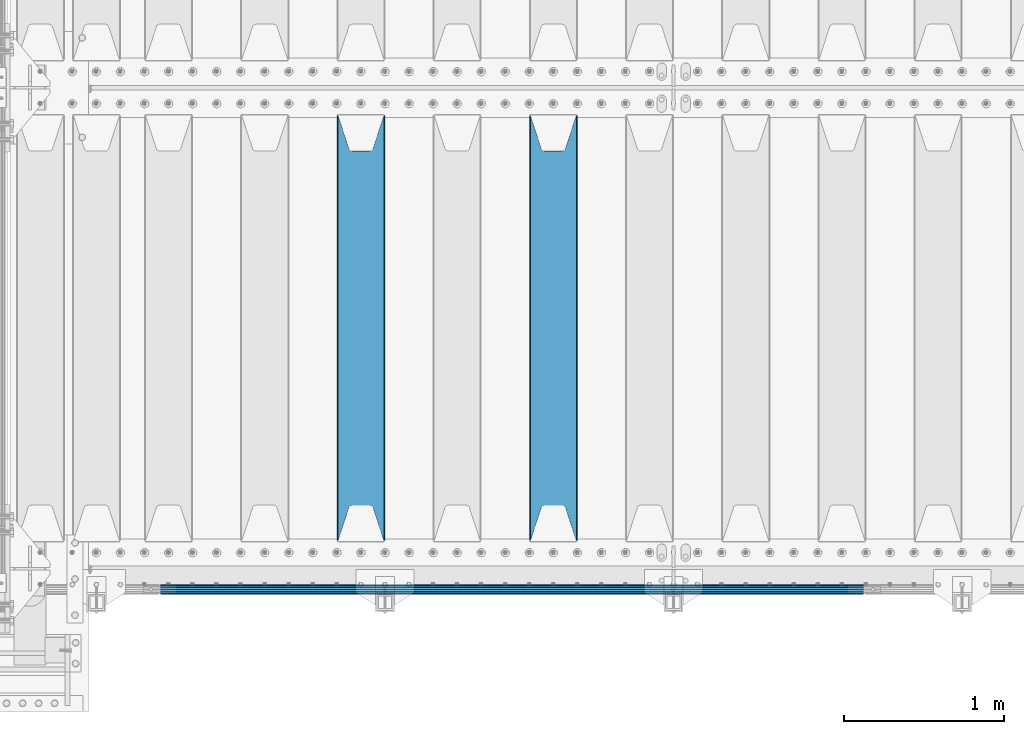
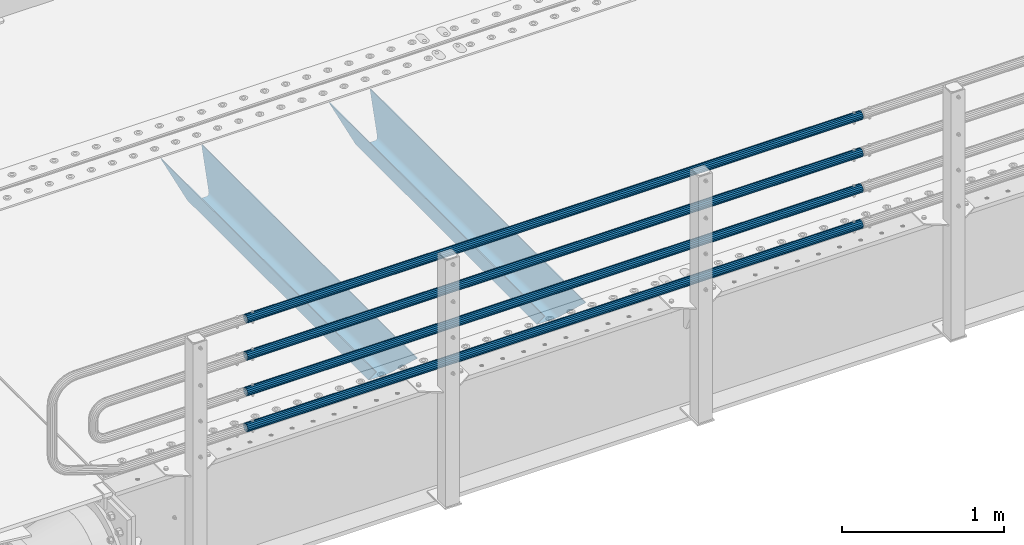
# One storey, part 86 of 193: 6 beams.
"""IFC2X3 building model written with IfcOpenShell, lengths in millimetres."""

from ifc_helpers import new_model, si_unit, frame, origin_with_axes, place, context, subcontext, project, spatial, faceted_brep, material, type_object, element, save


model = new_model("IFC2X3")

# Units and contexts
model_context = context("Model", 3, precision=1e-05, world=origin_with_axes())
body_context = subcontext(model_context, "Body", "Model", "MODEL_VIEW")
ifc_project = project(units=[si_unit("LENGTHUNIT", "METRE", prefix="MILLI"), si_unit("AREAUNIT", "SQUARE_METRE"), si_unit("VOLUMEUNIT", "CUBIC_METRE"), si_unit("MASSUNIT", "GRAM", prefix="KILO"), si_unit("TIMEUNIT", "SECOND"), si_unit("PLANEANGLEUNIT", "RADIAN"), si_unit("SOLIDANGLEUNIT", "STERADIAN"), si_unit("THERMODYNAMICTEMPERATUREUNIT", "DEGREE_CELSIUS"), si_unit("LUMINOUSINTENSITYUNIT", "LUMEN")], contexts=[model_context])

# Site, building, storey
site_placement = place(None, origin_with_axes())
site = spatial("IfcSite", under=ifc_project, at=site_placement, CompositionType="ELEMENT")
building_placement = place(site_placement, origin_with_axes())
building = spatial("IfcBuilding", under=site, at=building_placement, Name="Standard", CompositionType="ELEMENT")
storey_placement = place(building_placement, origin_with_axes())
storey = spatial("IfcBuildingStorey", under=building, at=storey_placement, Name="Undefined", CompositionType="ELEMENT", Elevation=0.0)

# Beams
ifc_material_1 = material(Name="STEEL/S355N")
beam_type_1 = type_object("IfcBeamType", PredefinedType="NOTDEFINED")
beam_1_placement = place(storey_placement, frame((-39050.0, 24175.0, -115.0), z_axis=(0.0, 0.0, 1.0), x_axis=(0.0, 1.0, 0.0)))
element("IfcBeam", 1, at=beam_1_placement, inside=storey, type_object=beam_type_1, material=ifc_material_1, context=body_context, shape_type="Brep", body=[
    faceted_brep([(0.0, 150.0, 115.0), (0.0, 143.689999999999, 115.0), (2650.00000000297, 143.689999999999, 115.0), (2650.00000000297, 150.0, 115.0), (2650.00000000297, 142.059565218398, 110.000000003094), (2650.00000000297, 148.3695652184, 110.000000003094), (2441.90079219209, -80.1103600731112, -98.0992078077845), (2437.7588105432, -77.5672621345584, -102.241189456673), (2434.06523489747, -74.4080125315522, -105.934765102404), (2430.9108609509, -70.710272125576, -109.089139048974), (2428.37322971128, -66.5649389910068, -111.626770288588), (2426.51472138055, -62.0739139532889, -113.485278619323), (2425.38102192092, -57.3475956567672, -114.618978078955), (2424.99999999988, -52.5021667386536, -115.0), (2424.99999999988, 52.5021667386536, -115.0), (2425.38102192092, 57.3475956567672, -114.618978078955), (2426.51472138055, 62.0739139532889, -113.485278619323), (2428.37322971128, 66.5649389910068, -111.626770288588), (2430.9108609509, 70.710272125576, -109.089139048974), (2434.06523489747, 74.4080125315522, -105.934765102404), (2437.7588105432, 77.5672621345584, -102.241189456673), (2441.90079219209, 80.1103600731112, -98.0992078077846), (2446.38936140512, 81.9747917625791, -93.6106385947584), (2448.2494850041, 76.2713538057251, -91.7505149957729), (2444.62967112263, 74.76777986261, -95.3703288772456), (2441.28936334127, 72.7168944282894, -98.710636658607), (2438.31067330439, 70.1691124903846, -101.689326695487), (2435.76682334748, 67.1870637758839, -104.233176652398), (2433.72034654134, 63.8440531834895, -106.279653458539), (2432.22154950042, 60.222258798236, -107.778450499454), (2431.30727574265, 56.4107117849089, -108.692724257221), (2430.99999999987, 52.5031078186876, -109.0), (2430.99999999987, -52.5031078186876, -109.0), (2431.30727574265, -56.4107117849089, -108.692724257221), (2432.22154950042, -60.222258798236, -107.778450499454), (2433.72034654134, -63.8440531834895, -106.279653458539), (2435.76682334748, -67.1870637758839, -104.233176652398), (2438.31067330439, -70.1691124903846, -101.689326695487), (2441.28936334127, -72.7168944282894, -98.7106366586071), (2444.62967112263, -74.76777986261, -95.3703288772457), (2448.2494850041, -76.2713538057251, -91.7505149957729), (2650.00000000297, -142.059565218398, 110.000000003094), (2650.00000000297, -148.3695652184, 110.000000003094), (2446.38936140512, -81.9747917625791, -93.6106385947584), (2650.00000000297, -143.689999999999, 115.0), (2650.00000000297, -150.0, 115.0), (0.0, -143.689999999999, 115.0), (0.0, -150.0, 115.0), (0.0, -148.369565218261, 110.000000002667), (203.610638597427, -81.9747917625791, -93.6106385947584), (208.099207810446, -80.1103600731112, -98.0992078077845), (212.241189459342, -77.5672621345584, -102.241189456673), (215.93476510507, -74.4080125315522, -105.934765102404), (219.089139051641, -70.710272125576, -109.089139048974), (221.626770291256, -66.5649389910068, -111.626770288588), (223.485278621989, -62.0739139532889, -113.485278619323), (224.618978081624, -57.3475956567672, -114.618978078955), (225.000000002663, -52.5021667386536, -115.0), (225.000000002663, 52.5021667386536, -115.0), (224.618978081624, 57.3475956567672, -114.618978078955), (223.485278621989, 62.0739139532889, -113.485278619323), (221.626770291256, 66.5649389910068, -111.626770288588), (219.089139051641, 70.710272125576, -109.089139048974), (215.93476510507, 74.4080125315522, -105.934765102404), (212.241189459342, 77.5672621345584, -102.241189456673), (208.099207810446, 80.1103600731112, -98.0992078077846), (203.610638597427, 81.9747917625791, -93.6106385947584), (0.0, 148.369565218261, 110.000000002667), (0.0, 142.05956521826, 110.000000002667), (201.750514998439, 76.2713538057251, -91.7505149957729), (205.370328879915, 74.76777986261, -95.3703288772456), (208.710636661275, 72.7168944282894, -98.710636658607), (211.689326698157, 70.1691124903846, -101.689326695487), (214.233176655063, 67.1870637758839, -104.233176652398), (216.279653461206, 63.8440531834895, -106.279653458539), (217.778450502123, 60.222258798236, -107.778450499454), (218.69272425989, 56.4107117849089, -108.692724257221), (219.00000000267, 52.5031078186876, -109.0), (219.00000000267, -52.5031078186876, -109.0), (218.69272425989, -56.4107117849089, -108.692724257221), (217.778450502123, -60.222258798236, -107.778450499454), (216.279653461206, -63.8440531834895, -106.279653458539), (214.233176655063, -67.1870637758839, -104.233176652398), (211.689326698157, -70.1691124903846, -101.689326695487), (208.710636661275, -72.7168944282894, -98.7106366586071), (205.370328879915, -74.76777986261, -95.3703288772457), (201.750514998439, -76.2713538057251, -91.7505149957729), (0.0, -142.05956521826, 110.000000002667)], [[[0, 1, 2, 3]], [[3, 2, 4, 5]], [[6, 7, 8, 9, 10, 11, 12, 13, 14, 15, 16, 17, 18, 19, 20, 21, 22, 5, 4, 23, 24, 25, 26, 27, 28, 29, 30, 31, 32, 33, 34, 35, 36, 37, 38, 39, 40, 41, 42, 43]], [[44, 45, 42, 41]], [[46, 47, 45, 44]], [[43, 42, 45, 47, 48, 49]], [[6, 43, 49, 50]], [[7, 6, 50, 51]], [[8, 7, 51, 52]], [[9, 8, 52, 53]], [[10, 9, 53, 54]], [[11, 10, 54, 55]], [[12, 11, 55, 56]], [[13, 12, 56, 57]], [[14, 13, 57, 58]], [[15, 14, 58, 59]], [[16, 15, 59, 60]], [[17, 16, 60, 61]], [[18, 17, 61, 62]], [[19, 18, 62, 63]], [[20, 19, 63, 64]], [[21, 20, 64, 65]], [[22, 21, 65, 66]], [[0, 3, 5, 22, 66, 67]], [[1, 0, 67, 68]], [[23, 4, 2, 1, 68, 69]], [[24, 23, 69, 70]], [[25, 24, 70, 71]], [[26, 25, 71, 72]], [[27, 26, 72, 73]], [[28, 27, 73, 74]], [[29, 28, 74, 75]], [[30, 29, 75, 76]], [[31, 30, 76, 77]], [[32, 31, 77, 78]], [[33, 32, 78, 79]], [[34, 33, 79, 80]], [[35, 34, 80, 81]], [[36, 35, 81, 82]], [[37, 36, 82, 83]], [[38, 37, 83, 84]], [[39, 38, 84, 85]], [[40, 39, 85, 86]], [[46, 44, 41, 40, 86, 87]], [[47, 46, 87, 48]], [[86, 85, 84, 83, 82, 81, 80, 79, 78, 77, 76, 75, 74, 73, 72, 71, 70, 69, 68, 67, 66, 65, 64, 63, 62, 61, 60, 59, 58, 57, 56, 55, 54, 53, 52, 51, 50, 49, 48, 87]]]),
])
beam_2_placement = place(storey_placement, frame((-40250.0, 24175.0, -115.0), z_axis=(0.0, 0.0, 1.0), x_axis=(0.0, 1.0, 0.0)))
element("IfcBeam", 2, at=beam_2_placement, inside=storey, type_object=beam_type_1, material=ifc_material_1, context=body_context, shape_type="Brep", body=[
    faceted_brep([(0.0, 150.0, 115.0), (0.0, 143.689999999999, 115.0), (2650.00000000297, 143.689999999999, 115.0), (2650.00000000297, 150.0, 115.0), (2650.00000000297, 142.059565218398, 110.000000003094), (2650.00000000297, 148.3695652184, 110.000000003094), (2441.90079219209, -80.1103600731112, -98.0992078077845), (2437.7588105432, -77.5672621345584, -102.241189456673), (2434.06523489747, -74.4080125315522, -105.934765102404), (2430.9108609509, -70.710272125576, -109.089139048974), (2428.37322971128, -66.5649389910068, -111.626770288588), (2426.51472138055, -62.0739139532889, -113.485278619323), (2425.38102192092, -57.3475956567672, -114.618978078955), (2424.99999999988, -52.5021667386536, -115.0), (2424.99999999988, 52.5021667386536, -115.0), (2425.38102192092, 57.3475956567672, -114.618978078955), (2426.51472138055, 62.0739139532889, -113.485278619323), (2428.37322971128, 66.5649389910068, -111.626770288588), (2430.9108609509, 70.710272125576, -109.089139048974), (2434.06523489747, 74.4080125315522, -105.934765102404), (2437.7588105432, 77.5672621345584, -102.241189456673), (2441.90079219209, 80.1103600731112, -98.0992078077846), (2446.38936140512, 81.9747917625791, -93.6106385947584), (2448.2494850041, 76.2713538057251, -91.7505149957729), (2444.62967112263, 74.76777986261, -95.3703288772456), (2441.28936334127, 72.7168944282894, -98.710636658607), (2438.31067330439, 70.1691124903846, -101.689326695487), (2435.76682334748, 67.1870637758839, -104.233176652398), (2433.72034654134, 63.8440531834895, -106.279653458539), (2432.22154950042, 60.222258798236, -107.778450499454), (2431.30727574265, 56.4107117849089, -108.692724257221), (2430.99999999987, 52.5031078186876, -109.0), (2430.99999999987, -52.5031078186876, -109.0), (2431.30727574265, -56.4107117849089, -108.692724257221), (2432.22154950042, -60.222258798236, -107.778450499454), (2433.72034654134, -63.8440531834895, -106.279653458539), (2435.76682334748, -67.1870637758839, -104.233176652398), (2438.31067330439, -70.1691124903846, -101.689326695487), (2441.28936334127, -72.7168944282894, -98.7106366586071), (2444.62967112263, -74.76777986261, -95.3703288772457), (2448.2494850041, -76.2713538057251, -91.7505149957729), (2650.00000000297, -142.059565218398, 110.000000003094), (2650.00000000297, -148.3695652184, 110.000000003094), (2446.38936140512, -81.9747917625791, -93.6106385947584), (2650.00000000297, -143.689999999999, 115.0), (2650.00000000297, -150.0, 115.0), (0.0, -143.689999999999, 115.0), (0.0, -150.0, 115.0), (0.0, -148.369565218261, 110.000000002667), (203.610638597427, -81.9747917625791, -93.6106385947584), (208.099207810446, -80.1103600731112, -98.0992078077845), (212.241189459342, -77.5672621345584, -102.241189456673), (215.93476510507, -74.4080125315522, -105.934765102404), (219.089139051641, -70.710272125576, -109.089139048974), (221.626770291256, -66.5649389910068, -111.626770288588), (223.485278621989, -62.0739139532889, -113.485278619323), (224.618978081624, -57.3475956567672, -114.618978078955), (225.000000002663, -52.5021667386536, -115.0), (225.000000002663, 52.5021667386536, -115.0), (224.618978081624, 57.3475956567672, -114.618978078955), (223.485278621989, 62.0739139532889, -113.485278619323), (221.626770291256, 66.5649389910068, -111.626770288588), (219.089139051641, 70.710272125576, -109.089139048974), (215.93476510507, 74.4080125315522, -105.934765102404), (212.241189459342, 77.5672621345584, -102.241189456673), (208.099207810446, 80.1103600731112, -98.0992078077846), (203.610638597427, 81.9747917625791, -93.6106385947584), (0.0, 148.369565218261, 110.000000002667), (0.0, 142.05956521826, 110.000000002667), (201.750514998439, 76.2713538057251, -91.7505149957729), (205.370328879915, 74.76777986261, -95.3703288772456), (208.710636661275, 72.7168944282894, -98.710636658607), (211.689326698157, 70.1691124903846, -101.689326695487), (214.233176655063, 67.1870637758839, -104.233176652398), (216.279653461206, 63.8440531834895, -106.279653458539), (217.778450502123, 60.222258798236, -107.778450499454), (218.69272425989, 56.4107117849089, -108.692724257221), (219.00000000267, 52.5031078186876, -109.0), (219.00000000267, -52.5031078186876, -109.0), (218.69272425989, -56.4107117849089, -108.692724257221), (217.778450502123, -60.222258798236, -107.778450499454), (216.279653461206, -63.8440531834895, -106.279653458539), (214.233176655063, -67.1870637758839, -104.233176652398), (211.689326698157, -70.1691124903846, -101.689326695487), (208.710636661275, -72.7168944282894, -98.7106366586071), (205.370328879915, -74.76777986261, -95.3703288772457), (201.750514998439, -76.2713538057251, -91.7505149957729), (0.0, -142.05956521826, 110.000000002667)], [[[0, 1, 2, 3]], [[3, 2, 4, 5]], [[6, 7, 8, 9, 10, 11, 12, 13, 14, 15, 16, 17, 18, 19, 20, 21, 22, 5, 4, 23, 24, 25, 26, 27, 28, 29, 30, 31, 32, 33, 34, 35, 36, 37, 38, 39, 40, 41, 42, 43]], [[44, 45, 42, 41]], [[46, 47, 45, 44]], [[43, 42, 45, 47, 48, 49]], [[6, 43, 49, 50]], [[7, 6, 50, 51]], [[8, 7, 51, 52]], [[9, 8, 52, 53]], [[10, 9, 53, 54]], [[11, 10, 54, 55]], [[12, 11, 55, 56]], [[13, 12, 56, 57]], [[14, 13, 57, 58]], [[15, 14, 58, 59]], [[16, 15, 59, 60]], [[17, 16, 60, 61]], [[18, 17, 61, 62]], [[19, 18, 62, 63]], [[20, 19, 63, 64]], [[21, 20, 64, 65]], [[22, 21, 65, 66]], [[0, 3, 5, 22, 66, 67]], [[1, 0, 67, 68]], [[23, 4, 2, 1, 68, 69]], [[24, 23, 69, 70]], [[25, 24, 70, 71]], [[26, 25, 71, 72]], [[27, 26, 72, 73]], [[28, 27, 73, 74]], [[29, 28, 74, 75]], [[30, 29, 75, 76]], [[31, 30, 76, 77]], [[32, 31, 77, 78]], [[33, 32, 78, 79]], [[34, 33, 79, 80]], [[35, 34, 80, 81]], [[36, 35, 81, 82]], [[37, 36, 82, 83]], [[38, 37, 83, 84]], [[39, 38, 84, 85]], [[40, 39, 85, 86]], [[46, 44, 41, 40, 86, 87]], [[47, 46, 87, 48]], [[86, 85, 84, 83, 82, 81, 80, 79, 78, 77, 76, 75, 74, 73, 72, 71, 70, 69, 68, 67, 66, 65, 64, 63, 62, 61, 60, 59, 58, 57, 56, 55, 54, 53, 52, 51, 50, 49, 48, 87]]]),
])
ifc_material_2 = material()
beam_type_2 = type_object("IfcBeamType", PredefinedType="NOTDEFINED")
beam_3_placement = place(storey_placement, frame((-37116.0000000001, 23870.1500000001, 149.849999999748), z_axis=(0.0, 0.0, -1.0), x_axis=(-1.0, 0.0, 0.0)))
element("IfcBeam", 3, at=beam_3_placement, inside=storey, type_object=beam_type_2, material=ifc_material_2, context=body_context, shape_type="Brep", body=[
    faceted_brep([(0.0, -26.5499999999993, 0.0), (0.0, -24.5290015881765, 10.1602451292931), (4384.00249699992, -24.5290015881765, 10.1602451292931), (4384.00249699992, -26.5499999999993, 0.0), (0.0, -18.7736850405017, 18.7736850405028), (4384.00249699992, -18.7736850405017, 18.7736850405028), (0.0, -10.1602451292929, 24.5290015881747), (4384.00249699992, -10.1602451292929, 24.5290015881747), (0.0, 0.0, 26.55), (4384.00249699992, 0.0, 26.55), (0.0, 10.1602451292929, 24.5290015881747), (4384.00249699992, 10.1602451292929, 24.5290015881747), (0.0, 18.7736850405017, 18.7736850405028), (4384.00249699992, 18.7736850405017, 18.7736850405028), (0.0, 24.5290015881765, 10.1602451292931), (4384.00249699992, 24.5290015881765, 10.1602451292931), (0.0, 26.5499999999993, 0.0), (4384.00249699992, 26.5499999999993, 0.0), (0.0, 24.5290015881765, -10.1602451292931), (4384.00249699992, 24.5290015881765, -10.1602451292931), (0.0, 18.7736850405017, -18.7736850405028), (4384.00249699992, 18.7736850405017, -18.7736850405028), (0.0, 10.1602451292929, -24.5290015881747), (4384.00249699992, 10.1602451292929, -24.5290015881747), (0.0, 0.0, -26.55), (4384.00249699992, 0.0, -26.55), (0.0, -10.1602451292929, -24.5290015881747), (4384.00249699992, -10.1602451292929, -24.5290015881747), (0.0, -18.7736850405017, -18.7736850405028), (4384.00249699992, -18.7736850405017, -18.7736850405028), (0.0, -24.5290015881765, -10.1602451292931), (4384.00249699992, -24.5290015881765, -10.1602451292931), (0.0, -30.1500000000015, 0.0), (0.0, -27.8549679052157, -11.5379054858058), (4384.00249699992, -27.8549679052157, -11.5379054858075), (4384.00249699992, -30.1500000000015, 0.0), (0.0, -21.3192694527752, -21.3192694527752), (4384.00249699992, -21.3192694527752, -21.3192694527744), (0.0, -11.5379054858058, -27.8549679052157), (4384.00249699992, -11.5379054858058, -27.8549679052153), (0.0, 0.0, -30.1500000000015), (4384.00249699992, 0.0, -30.15), (0.0, 11.5379054858058, -27.8549679052157), (4384.00249699992, 11.5379054858058, -27.8549679052153), (0.0, 21.3192694527752, -21.3192694527752), (4384.00249699992, 21.3192694527752, -21.3192694527744), (0.0, 27.8549679052157, -11.5379054858058), (4384.00249699992, 27.8549679052157, -11.5379054858074), (0.0, 30.1500000000015, 0.0), (4384.00249699992, 30.1500000000015, 0.0), (0.0, 27.8549679052157, 11.5379054858058), (4384.00249699992, 27.8549679052157, 11.5379054858075), (0.0, 21.3192694527752, 21.3192694527752), (4384.00249699992, 21.3192694527752, 21.3192694527744), (0.0, 11.5379054858058, 27.8549679052157), (4384.00249699992, 11.5379054858058, 27.8549679052153), (0.0, 0.0, 30.1500000000015), (4384.00249699992, 0.0, 30.15), (0.0, -11.5379054858058, 27.8549679052157), (4384.00249699992, -11.5379054858058, 27.8549679052153), (0.0, -21.3192694527752, 21.3192694527752), (4384.00249699992, -21.3192694527752, 21.3192694527744), (0.0, -27.8549679052157, 11.5379054858058), (4384.00249699992, -27.8549679052157, 11.5379054858075)], [[[0, 1, 2, 3]], [[1, 4, 5, 2]], [[4, 6, 7, 5]], [[6, 8, 9, 7]], [[8, 10, 11, 9]], [[10, 12, 13, 11]], [[12, 14, 15, 13]], [[14, 16, 17, 15]], [[16, 18, 19, 17]], [[18, 20, 21, 19]], [[20, 22, 23, 21]], [[22, 24, 25, 23]], [[24, 26, 27, 25]], [[26, 28, 29, 27]], [[28, 30, 31, 29]], [[30, 0, 3, 31]], [[32, 33, 34, 35]], [[33, 36, 37, 34]], [[36, 38, 39, 37]], [[38, 40, 41, 39]], [[40, 42, 43, 41]], [[42, 44, 45, 43]], [[44, 46, 47, 45]], [[46, 48, 49, 47]], [[48, 50, 51, 49]], [[50, 52, 53, 51]], [[52, 54, 55, 53]], [[54, 56, 57, 55]], [[56, 58, 59, 57]], [[58, 60, 61, 59]], [[60, 62, 63, 61]], [[62, 32, 35, 63]], [[37, 39, 41, 43, 45, 47, 49, 51, 53, 55, 57, 59, 61, 63, 35, 34], [5, 7, 9, 11, 13, 15, 17, 19, 21, 23, 25, 27, 29, 31, 3, 2]], [[62, 60, 58, 56, 54, 52, 50, 48, 46, 44, 42, 40, 38, 36, 33, 32], [30, 28, 26, 24, 22, 20, 18, 16, 14, 12, 10, 8, 6, 4, 1, 0]]]),
])
beam_4_placement = place(storey_placement, frame((-37116.0000000001, 23870.1500000001, 420.149999999748), z_axis=(0.0, 0.0, -1.0), x_axis=(-1.0, 0.0, 0.0)))
element("IfcBeam", 4, at=beam_4_placement, inside=storey, type_object=beam_type_2, material=ifc_material_2, context=body_context, shape_type="Brep", body=[
    faceted_brep([(0.0, -26.5499999999993, 0.0), (0.0, -24.5290015881765, 10.1602451292931), (4384.00249699992, -24.5290015881765, 10.1602451292931), (4384.00249699992, -26.5499999999993, 0.0), (0.0, -18.7736850405017, 18.7736850405028), (4384.00249699992, -18.7736850405017, 18.7736850405028), (0.0, -10.1602451292929, 24.5290015881747), (4384.00249699992, -10.1602451292929, 24.5290015881747), (0.0, 0.0, 26.55), (4384.00249699992, 0.0, 26.55), (0.0, 10.1602451292929, 24.5290015881747), (4384.00249699992, 10.1602451292929, 24.5290015881747), (0.0, 18.7736850405017, 18.7736850405028), (4384.00249699992, 18.7736850405017, 18.7736850405028), (0.0, 24.5290015881765, 10.1602451292931), (4384.00249699992, 24.5290015881765, 10.1602451292931), (0.0, 26.5499999999993, 0.0), (4384.00249699992, 26.5499999999993, 0.0), (0.0, 24.5290015881765, -10.1602451292931), (4384.00249699992, 24.5290015881765, -10.1602451292931), (0.0, 18.7736850405017, -18.7736850405028), (4384.00249699992, 18.7736850405017, -18.7736850405028), (0.0, 10.1602451292929, -24.5290015881747), (4384.00249699992, 10.1602451292929, -24.5290015881747), (0.0, 0.0, -26.55), (4384.00249699992, 0.0, -26.55), (0.0, -10.1602451292929, -24.5290015881747), (4384.00249699992, -10.1602451292929, -24.5290015881747), (0.0, -18.7736850405017, -18.7736850405028), (4384.00249699992, -18.7736850405017, -18.7736850405028), (0.0, -24.5290015881765, -10.1602451292931), (4384.00249699992, -24.5290015881765, -10.1602451292931), (0.0, -30.1500000000015, 0.0), (0.0, -27.8549679052157, -11.5379054858058), (4384.00249699992, -27.8549679052157, -11.5379054858075), (4384.00249699992, -30.1500000000015, 0.0), (0.0, -21.3192694527752, -21.3192694527752), (4384.00249699992, -21.3192694527752, -21.3192694527744), (0.0, -11.5379054858058, -27.8549679052157), (4384.00249699992, -11.5379054858058, -27.8549679052153), (0.0, 0.0, -30.1500000000015), (4384.00249699992, 0.0, -30.15), (0.0, 11.5379054858058, -27.8549679052157), (4384.00249699992, 11.5379054858058, -27.8549679052153), (0.0, 21.3192694527752, -21.3192694527752), (4384.00249699992, 21.3192694527752, -21.3192694527744), (0.0, 27.8549679052157, -11.5379054858058), (4384.00249699992, 27.8549679052157, -11.5379054858074), (0.0, 30.1500000000015, 0.0), (4384.00249699992, 30.1500000000015, 0.0), (0.0, 27.8549679052157, 11.5379054858058), (4384.00249699992, 27.8549679052157, 11.5379054858075), (0.0, 21.3192694527752, 21.3192694527752), (4384.00249699992, 21.3192694527752, 21.3192694527744), (0.0, 11.5379054858058, 27.8549679052157), (4384.00249699992, 11.5379054858058, 27.8549679052153), (0.0, 0.0, 30.1500000000015), (4384.00249699992, 0.0, 30.15), (0.0, -11.5379054858058, 27.8549679052157), (4384.00249699992, -11.5379054858058, 27.8549679052153), (0.0, -21.3192694527752, 21.3192694527752), (4384.00249699992, -21.3192694527752, 21.3192694527744), (0.0, -27.8549679052157, 11.5379054858058), (4384.00249699992, -27.8549679052157, 11.5379054858075)], [[[0, 1, 2, 3]], [[1, 4, 5, 2]], [[4, 6, 7, 5]], [[6, 8, 9, 7]], [[8, 10, 11, 9]], [[10, 12, 13, 11]], [[12, 14, 15, 13]], [[14, 16, 17, 15]], [[16, 18, 19, 17]], [[18, 20, 21, 19]], [[20, 22, 23, 21]], [[22, 24, 25, 23]], [[24, 26, 27, 25]], [[26, 28, 29, 27]], [[28, 30, 31, 29]], [[30, 0, 3, 31]], [[32, 33, 34, 35]], [[33, 36, 37, 34]], [[36, 38, 39, 37]], [[38, 40, 41, 39]], [[40, 42, 43, 41]], [[42, 44, 45, 43]], [[44, 46, 47, 45]], [[46, 48, 49, 47]], [[48, 50, 51, 49]], [[50, 52, 53, 51]], [[52, 54, 55, 53]], [[54, 56, 57, 55]], [[56, 58, 59, 57]], [[58, 60, 61, 59]], [[60, 62, 63, 61]], [[62, 32, 35, 63]], [[37, 39, 41, 43, 45, 47, 49, 51, 53, 55, 57, 59, 61, 63, 35, 34], [5, 7, 9, 11, 13, 15, 17, 19, 21, 23, 25, 27, 29, 31, 3, 2]], [[62, 60, 58, 56, 54, 52, 50, 48, 46, 44, 42, 40, 38, 36, 33, 32], [30, 28, 26, 24, 22, 20, 18, 16, 14, 12, 10, 8, 6, 4, 1, 0]]]),
])
beam_5_placement = place(storey_placement, frame((-37116.0000000001, 23870.1500000001, 969.849999999748), z_axis=(0.0, 0.0, -1.0), x_axis=(-1.0, 0.0, 0.0)))
element("IfcBeam", 5, at=beam_5_placement, inside=storey, type_object=beam_type_2, material=ifc_material_2, context=body_context, shape_type="Brep", body=[
    faceted_brep([(0.0, -26.5499999999993, 0.0), (0.0, -24.5290015881765, 10.1602451292931), (4384.00249699992, -24.5290015881765, 10.1602451292931), (4384.00249699992, -26.5499999999993, 0.0), (0.0, -18.7736850405017, 18.7736850405028), (4384.00249699992, -18.7736850405017, 18.7736850405028), (0.0, -10.1602451292929, 24.5290015881747), (4384.00249699992, -10.1602451292929, 24.5290015881747), (0.0, 0.0, 26.55), (4384.00249699992, 0.0, 26.55), (0.0, 10.1602451292929, 24.5290015881747), (4384.00249699992, 10.1602451292929, 24.5290015881747), (0.0, 18.7736850405017, 18.7736850405028), (4384.00249699992, 18.7736850405017, 18.7736850405028), (0.0, 24.5290015881765, 10.1602451292931), (4384.00249699992, 24.5290015881765, 10.1602451292931), (0.0, 26.5499999999993, 0.0), (4384.00249699992, 26.5499999999993, 0.0), (0.0, 24.5290015881765, -10.1602451292931), (4384.00249699992, 24.5290015881765, -10.1602451292931), (0.0, 18.7736850405017, -18.7736850405028), (4384.00249699992, 18.7736850405017, -18.7736850405028), (0.0, 10.1602451292929, -24.5290015881747), (4384.00249699992, 10.1602451292929, -24.5290015881747), (0.0, 0.0, -26.55), (4384.00249699992, 0.0, -26.55), (0.0, -10.1602451292929, -24.5290015881747), (4384.00249699992, -10.1602451292929, -24.5290015881747), (0.0, -18.7736850405017, -18.7736850405028), (4384.00249699992, -18.7736850405017, -18.7736850405028), (0.0, -24.5290015881765, -10.1602451292931), (4384.00249699992, -24.5290015881765, -10.1602451292931), (0.0, -30.1500000000015, 0.0), (0.0, -27.8549679052157, -11.5379054858058), (4384.00249699992, -27.8549679052157, -11.5379054858075), (4384.00249699992, -30.1500000000015, 0.0), (0.0, -21.3192694527752, -21.3192694527752), (4384.00249699992, -21.3192694527752, -21.3192694527744), (0.0, -11.5379054858058, -27.8549679052157), (4384.00249699992, -11.5379054858058, -27.8549679052153), (0.0, 0.0, -30.1500000000015), (4384.00249699992, 0.0, -30.15), (0.0, 11.5379054858058, -27.8549679052157), (4384.00249699992, 11.5379054858058, -27.8549679052153), (0.0, 21.3192694527752, -21.3192694527752), (4384.00249699992, 21.3192694527752, -21.3192694527744), (0.0, 27.8549679052157, -11.5379054858058), (4384.00249699992, 27.8549679052157, -11.5379054858074), (0.0, 30.1500000000015, 0.0), (4384.00249699992, 30.1500000000015, 0.0), (0.0, 27.8549679052157, 11.5379054858058), (4384.00249699992, 27.8549679052157, 11.5379054858075), (0.0, 21.3192694527752, 21.3192694527752), (4384.00249699992, 21.3192694527752, 21.3192694527744), (0.0, 11.5379054858058, 27.8549679052157), (4384.00249699992, 11.5379054858058, 27.8549679052153), (0.0, 0.0, 30.1500000000015), (4384.00249699992, 0.0, 30.15), (0.0, -11.5379054858058, 27.8549679052157), (4384.00249699992, -11.5379054858058, 27.8549679052153), (0.0, -21.3192694527752, 21.3192694527752), (4384.00249699992, -21.3192694527752, 21.3192694527744), (0.0, -27.8549679052157, 11.5379054858058), (4384.00249699992, -27.8549679052157, 11.5379054858075)], [[[0, 1, 2, 3]], [[1, 4, 5, 2]], [[4, 6, 7, 5]], [[6, 8, 9, 7]], [[8, 10, 11, 9]], [[10, 12, 13, 11]], [[12, 14, 15, 13]], [[14, 16, 17, 15]], [[16, 18, 19, 17]], [[18, 20, 21, 19]], [[20, 22, 23, 21]], [[22, 24, 25, 23]], [[24, 26, 27, 25]], [[26, 28, 29, 27]], [[28, 30, 31, 29]], [[30, 0, 3, 31]], [[32, 33, 34, 35]], [[33, 36, 37, 34]], [[36, 38, 39, 37]], [[38, 40, 41, 39]], [[40, 42, 43, 41]], [[42, 44, 45, 43]], [[44, 46, 47, 45]], [[46, 48, 49, 47]], [[48, 50, 51, 49]], [[50, 52, 53, 51]], [[52, 54, 55, 53]], [[54, 56, 57, 55]], [[56, 58, 59, 57]], [[58, 60, 61, 59]], [[60, 62, 63, 61]], [[62, 32, 35, 63]], [[37, 39, 41, 43, 45, 47, 49, 51, 53, 55, 57, 59, 61, 63, 35, 34], [5, 7, 9, 11, 13, 15, 17, 19, 21, 23, 25, 27, 29, 31, 3, 2]], [[62, 60, 58, 56, 54, 52, 50, 48, 46, 44, 42, 40, 38, 36, 33, 32], [30, 28, 26, 24, 22, 20, 18, 16, 14, 12, 10, 8, 6, 4, 1, 0]]]),
])
beam_6_placement = place(storey_placement, frame((-37116.0000000001, 23870.1500000001, 689.849999999748), z_axis=(0.0, 0.0, -1.0), x_axis=(-1.0, 0.0, 0.0)))
element("IfcBeam", 6, at=beam_6_placement, inside=storey, type_object=beam_type_2, material=ifc_material_2, context=body_context, shape_type="Brep", body=[
    faceted_brep([(0.0, -26.5499999999993, 0.0), (0.0, -24.5290015881765, 10.1602451292931), (4384.00249699992, -24.5290015881765, 10.1602451292931), (4384.00249699992, -26.5499999999993, 0.0), (0.0, -18.7736850405017, 18.7736850405028), (4384.00249699992, -18.7736850405017, 18.7736850405028), (0.0, -10.1602451292929, 24.5290015881747), (4384.00249699992, -10.1602451292929, 24.5290015881747), (0.0, 0.0, 26.55), (4384.00249699992, 0.0, 26.55), (0.0, 10.1602451292929, 24.5290015881747), (4384.00249699992, 10.1602451292929, 24.5290015881747), (0.0, 18.7736850405017, 18.7736850405028), (4384.00249699992, 18.7736850405017, 18.7736850405028), (0.0, 24.5290015881765, 10.1602451292931), (4384.00249699992, 24.5290015881765, 10.1602451292931), (0.0, 26.5499999999993, 0.0), (4384.00249699992, 26.5499999999993, 0.0), (0.0, 24.5290015881765, -10.1602451292931), (4384.00249699992, 24.5290015881765, -10.1602451292931), (0.0, 18.7736850405017, -18.7736850405028), (4384.00249699992, 18.7736850405017, -18.7736850405028), (0.0, 10.1602451292929, -24.5290015881747), (4384.00249699992, 10.1602451292929, -24.5290015881747), (0.0, 0.0, -26.55), (4384.00249699992, 0.0, -26.55), (0.0, -10.1602451292929, -24.5290015881747), (4384.00249699992, -10.1602451292929, -24.5290015881747), (0.0, -18.7736850405017, -18.7736850405028), (4384.00249699992, -18.7736850405017, -18.7736850405028), (0.0, -24.5290015881765, -10.1602451292931), (4384.00249699992, -24.5290015881765, -10.1602451292931), (0.0, -30.1500000000015, 0.0), (0.0, -27.8549679052157, -11.5379054858058), (4384.00249699992, -27.8549679052157, -11.5379054858075), (4384.00249699992, -30.1500000000015, 0.0), (0.0, -21.3192694527752, -21.3192694527752), (4384.00249699992, -21.3192694527752, -21.3192694527744), (0.0, -11.5379054858058, -27.8549679052157), (4384.00249699992, -11.5379054858058, -27.8549679052153), (0.0, 0.0, -30.1500000000015), (4384.00249699992, 0.0, -30.15), (0.0, 11.5379054858058, -27.8549679052157), (4384.00249699992, 11.5379054858058, -27.8549679052153), (0.0, 21.3192694527752, -21.3192694527752), (4384.00249699992, 21.3192694527752, -21.3192694527744), (0.0, 27.8549679052157, -11.5379054858058), (4384.00249699992, 27.8549679052157, -11.5379054858074), (0.0, 30.1500000000015, 0.0), (4384.00249699992, 30.1500000000015, 0.0), (0.0, 27.8549679052157, 11.5379054858058), (4384.00249699992, 27.8549679052157, 11.5379054858075), (0.0, 21.3192694527752, 21.3192694527752), (4384.00249699992, 21.3192694527752, 21.3192694527744), (0.0, 11.5379054858058, 27.8549679052157), (4384.00249699992, 11.5379054858058, 27.8549679052153), (0.0, 0.0, 30.1500000000015), (4384.00249699992, 0.0, 30.15), (0.0, -11.5379054858058, 27.8549679052157), (4384.00249699992, -11.5379054858058, 27.8549679052153), (0.0, -21.3192694527752, 21.3192694527752), (4384.00249699992, -21.3192694527752, 21.3192694527744), (0.0, -27.8549679052157, 11.5379054858058), (4384.00249699992, -27.8549679052157, 11.5379054858075)], [[[0, 1, 2, 3]], [[1, 4, 5, 2]], [[4, 6, 7, 5]], [[6, 8, 9, 7]], [[8, 10, 11, 9]], [[10, 12, 13, 11]], [[12, 14, 15, 13]], [[14, 16, 17, 15]], [[16, 18, 19, 17]], [[18, 20, 21, 19]], [[20, 22, 23, 21]], [[22, 24, 25, 23]], [[24, 26, 27, 25]], [[26, 28, 29, 27]], [[28, 30, 31, 29]], [[30, 0, 3, 31]], [[32, 33, 34, 35]], [[33, 36, 37, 34]], [[36, 38, 39, 37]], [[38, 40, 41, 39]], [[40, 42, 43, 41]], [[42, 44, 45, 43]], [[44, 46, 47, 45]], [[46, 48, 49, 47]], [[48, 50, 51, 49]], [[50, 52, 53, 51]], [[52, 54, 55, 53]], [[54, 56, 57, 55]], [[56, 58, 59, 57]], [[58, 60, 61, 59]], [[60, 62, 63, 61]], [[62, 32, 35, 63]], [[37, 39, 41, 43, 45, 47, 49, 51, 53, 55, 57, 59, 61, 63, 35, 34], [5, 7, 9, 11, 13, 15, 17, 19, 21, 23, 25, 27, 29, 31, 3, 2]], [[62, 60, 58, 56, 54, 52, 50, 48, 46, 44, 42, 40, 38, 36, 33, 32], [30, 28, 26, 24, 22, 20, 18, 16, 14, 12, 10, 8, 6, 4, 1, 0]]]),
])

save(model, "model.ifc")
